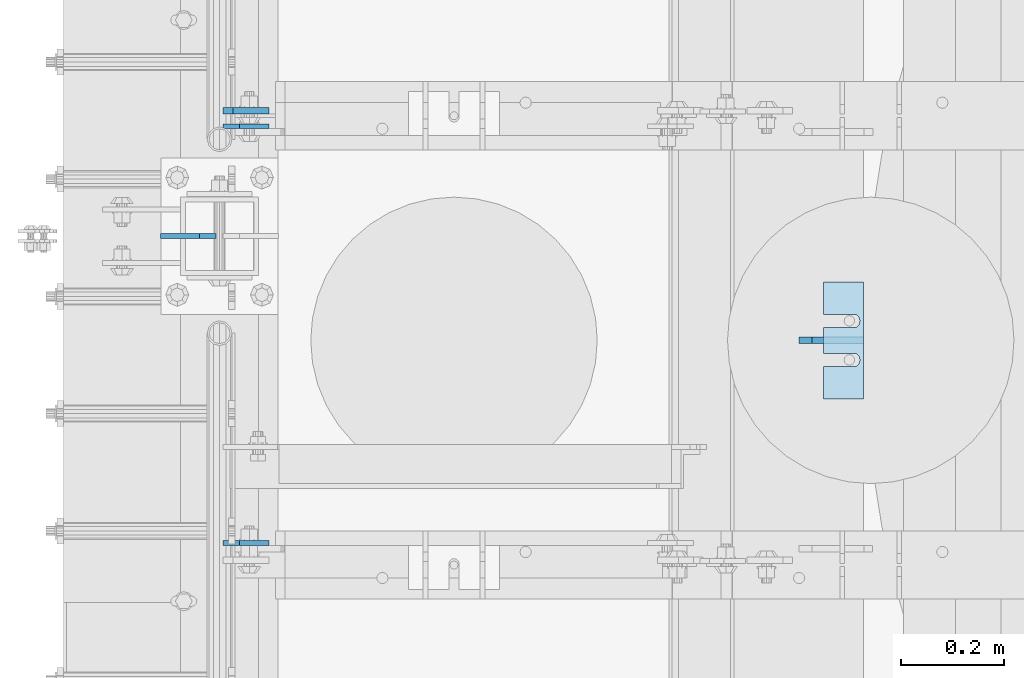
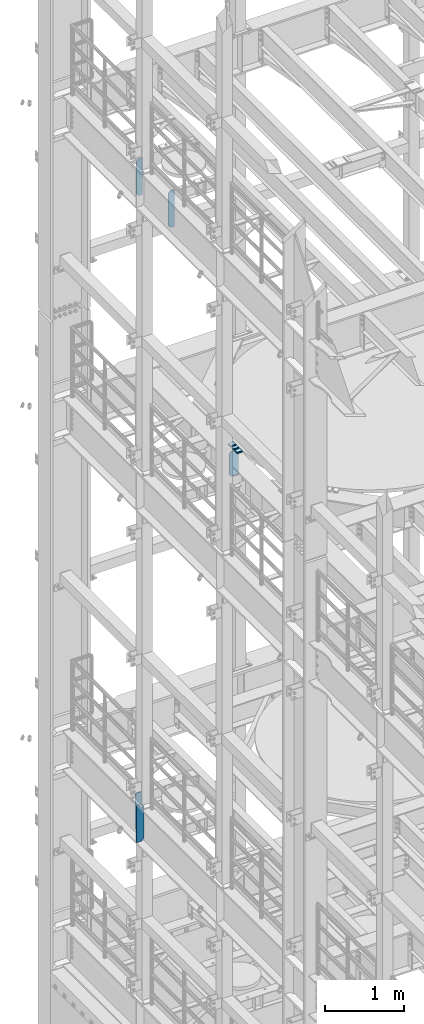
# One storey, part 1757 of 1876: 11 plates, 9 elements without a shape of their own.
"""IFC2X3 building model written with IfcOpenShell, lengths in millimetres."""

from ifc_helpers import new_model, si_unit, frame, origin_with_axes, place, context, subcontext, project, spatial, faceted_brep, material, type_object, element, aggregate, save


model = new_model("IFC2X3")

# Units and contexts
model_context = context("Model", 3, precision=1e-05, world=origin_with_axes())
body_context = subcontext(model_context, "Body", "Model", "MODEL_VIEW")
ifc_project = project(units=[si_unit("LENGTHUNIT", "METRE", prefix="MILLI"), si_unit("AREAUNIT", "SQUARE_METRE"), si_unit("VOLUMEUNIT", "CUBIC_METRE"), si_unit("MASSUNIT", "GRAM", prefix="KILO"), si_unit("TIMEUNIT", "SECOND"), si_unit("PLANEANGLEUNIT", "RADIAN"), si_unit("SOLIDANGLEUNIT", "STERADIAN"), si_unit("THERMODYNAMICTEMPERATUREUNIT", "DEGREE_CELSIUS"), si_unit("LUMINOUSINTENSITYUNIT", "LUMEN")], contexts=[model_context])

# Site, building, storey
site_placement = place(None, origin_with_axes())
site = spatial("IfcSite", under=ifc_project, at=site_placement, CompositionType="ELEMENT")
building_placement = place(site_placement, origin_with_axes())
building = spatial("IfcBuilding", under=site, at=building_placement, Name="Undefined", CompositionType="ELEMENT")
storey_placement = place(building_placement, origin_with_axes())
storey = spatial("IfcBuildingStorey", under=building, at=storey_placement, Name="Undefined", CompositionType="ELEMENT", Elevation=0.0)

# Assembly, plates
assembly_1_placement = place(storey_placement, origin_with_axes())
assembly_1 = element("IfcElementAssembly", 1, at=assembly_1_placement, inside=storey, Name="BEAM", AssemblyPlace="NOTDEFINED", PredefinedType="RIGID_FRAME")
ifc_material = material(Name="STEEL/A36")
plate_type_1 = type_object("IfcPlateType", PredefinedType="NOTDEFINED")
plate_1_placement = place(assembly_1_placement, frame((7.14374999999999, 11085.5129999161, 17386.3), z_axis=(0.0, 0.0, 1.0), x_axis=(1.0, 0.0, 0.0)))
plate_1 = element("IfcPlate", 2, at=plate_1_placement, type_object=plate_type_1, material=ifc_material, Name="PLATE", context=body_context, shape_type="Brep", body=[
    faceted_brep([(-9.76996261670138e-14, -4.76250000000073, 31.75), (0.0, -4.76249999999982, 539.75), (0.0, 4.76249999999982, 539.75), (-9.76996261670138e-14, 4.76250000000073, 31.75), (31.75, -4.76249999999982, 571.5), (31.75, 4.76249999999982, 571.5), (88.9000015258789, -4.76250000000005, 571.5), (88.9000015258789, 4.76250000000005, 571.5), (88.9000015258789, -4.76249999999982, 0.0), (88.9000015258789, 4.76249999999982, 0.0), (31.75, -4.76250000000073, 0.0), (31.75, 4.76250000000073, 0.0)], [[[0, 1, 2, 3]], [[1, 4, 5, 2]], [[4, 6, 7, 5]], [[6, 8, 9, 7]], [[8, 10, 11, 9]], [[10, 0, 3, 11]], [[5, 7, 9, 11, 3, 2]], [[10, 8, 6, 4, 1, 0]]]),
])
plate_2_placement = place(assembly_1_placement, frame((7.14374999999999, 11898.3102777481, 17386.3), z_axis=(0.0, 0.0, 1.0), x_axis=(1.0, 0.0, 0.0)))
plate_2 = element("IfcPlate", 3, at=plate_2_placement, type_object=plate_type_1, material=ifc_material, Name="PLATE", context=body_context, shape_type="Brep", body=[
    faceted_brep([(-9.76996261670138e-14, -4.76250000000073, 31.75), (0.0, -4.76249999999982, 539.75), (0.0, 4.76249999999982, 539.75), (-9.76996261670138e-14, 4.76250000000073, 31.75), (31.75, -4.76249999999982, 571.5), (31.75, 4.76249999999982, 571.5), (88.9000015258789, -4.76250000000005, 571.5), (88.9000015258789, 4.76250000000005, 571.5), (88.9000015258789, -4.76249999999982, 0.0), (88.9000015258789, 4.76249999999982, 0.0), (31.75, -4.76250000000073, 0.0), (31.75, 4.76250000000073, 0.0)], [[[0, 1, 2, 3]], [[1, 4, 5, 2]], [[4, 6, 7, 5]], [[6, 8, 9, 7]], [[8, 10, 11, 9]], [[10, 0, 3, 11]], [[5, 7, 9, 11, 3, 2]], [[10, 8, 6, 4, 1, 0]]]),
])
aggregate(assembly_1, [plate_1, plate_2])

# Assembly, plate
assembly_2_placement = place(storey_placement, origin_with_axes())
assembly_2 = element("IfcElementAssembly", 4, at=assembly_2_placement, inside=storey, Name="BEAM", AssemblyPlace="NOTDEFINED", PredefinedType="RIGID_FRAME")
plate_type_2 = type_object("IfcPlateType", PredefinedType="NOTDEFINED")
plate_3_placement = place(assembly_2_placement, frame((7.14375000000001, 11928.475, 7558.0875), z_axis=(0.0, 0.0, 1.0), x_axis=(1.0, 0.0, 0.0)))
plate_3 = element("IfcPlate", 5, at=plate_3_placement, type_object=plate_type_2, material=ifc_material, Name="PLATE", context=body_context, shape_type="Brep", body=[
    faceted_brep([(0.0, -6.35000000000196, 19.0499992370605), (0.0, -6.34999999999991, 550.862476348877), (0.0, 6.34999999999991, 550.862476348877), (0.0, 6.35000000000105, 19.0499992370605), (19.0499992370605, -6.34999999999991, 569.912475585938), (19.0499992370605, 6.34999999999991, 569.912475585938), (88.9000015258616, -6.35000000001173, 569.912475585938), (88.9000015258634, 6.34999999998627, 569.912475585938), (88.9000015258789, -6.34999999999991, 0.0), (88.9000015258789, 6.34999999999991, 0.0), (19.0499992370642, -6.35000000000105, 0.0), (19.0499992370633, 6.35000000000105, 0.0)], [[[0, 1, 2, 3]], [[1, 4, 5, 2]], [[4, 6, 7, 5]], [[6, 8, 9, 7]], [[8, 10, 11, 9]], [[10, 0, 3, 11]], [[5, 7, 9, 11, 3, 2]], [[10, 8, 6, 4, 1, 0]]]),
])

assembly_3_placement = place(storey_placement, origin_with_axes())
assembly_3 = element("IfcElementAssembly", 6, at=assembly_3_placement, inside=storey, Name="SHIM PLATE", AssemblyPlace="NOTDEFINED", PredefinedType="RIGID_FRAME")
plate_type_3 = type_object("IfcPlateType", PredefinedType="NOTDEFINED")
plate_4_placement = place(assembly_3_placement, frame((1177.56835632324, 11366.5000039719, 13335.7925), z_axis=(2.39509999928487e-05, 0.999999999713175, 0.0), x_axis=(0.999999999713175, -2.395099999284e-05, 0.0)))
plate_4 = element("IfcPlate", 7, at=plate_4_placement, type_object=plate_type_3, material=ifc_material, Name="SHIM PLATE", context=body_context, shape_type="Brep", body=[
    faceted_brep([(-2.69435986410826e-07, -0.793499999999767, 88.9036802523933), (-2.69435986410826e-07, 0.793499999999767, 88.9036802523933), (64.2890073715625, 0.793499999999767, 88.9052190745724), (64.2890073715625, -0.793499999999767, 88.9052190745724), (69.5243873298787, 0.793499999999767, 83.4915584105911), (69.5243873298787, -0.793499999999767, 83.4915584105911), (64.2896161919252, -0.793499999999767, 63.5071916498637), (64.2896161919252, 0.793499999999767, 63.5071916498637), (-1.92456354852766e-07, 0.793499999999767, 63.5036806291719), (-1.92456354852766e-07, -0.793499999999767, 63.5036806291719), (69.5247366006915, -0.793499999999767, 68.9211033039346), (69.5247366006915, 0.793499999999767, 68.9211033039346), (71.4330651893342, -0.793499999999767, 76.2063766063075), (71.4330651893342, 0.793499999999767, 76.2063766063075), (64.2877911166179, -0.793499999999767, 139.707191628078), (64.2877911166179, 0.793499999999767, 139.707191628078), (-4.23393430537544e-07, 0.793499999999767, 139.703680607393), (-4.23393430537544e-07, -0.793499999999767, 139.703680607393), (69.522911525386, -0.793499999999767, 145.12110328215), (69.522911525386, 0.793499999999767, 145.12110328215), (71.4312401140269, -0.793499999999767, 152.406376584524), (71.4312401140269, 0.793499999999767, 152.406376584524), (69.5225622545713, -0.793499999999767, 159.691558388807), (69.5225622545713, 0.793499999999767, 159.691558388807), (64.287182296257, -0.793499999999767, 165.105219052788), (64.287182296257, 0.793499999999767, 165.105219052788), (-5.00373062095605e-07, -0.793499999999767, 165.103680230615), (-5.00373062095605e-07, 0.793499999999767, 165.103680230615), (-6.92811227054335e-07, -0.793499999999767, 228.601303100698), (-6.92811227054335e-07, 0.793499999999767, 228.601303100698), (78.1460113524699, -0.793499999999767, 228.601303100651), (78.1460113524699, 0.793499999999767, 228.601303100651), (78.1460113525918, -0.793499999999767, -4.91127138957381e-11), (78.1460113525918, 0.793499999999767, -4.91127138957381e-11), (9.09494701772928e-13, -0.793499999999767, 0.0), (9.09494701772928e-13, 0.793499999999767, 0.0)], [[[0, 1, 2, 3]], [[3, 2, 4, 5]], [[6, 7, 8, 9]], [[10, 11, 7, 6]], [[12, 13, 11, 10]], [[5, 4, 13, 12]], [[14, 15, 16, 17]], [[18, 19, 15, 14]], [[20, 21, 19, 18]], [[22, 23, 21, 20]], [[24, 25, 23, 22]], [[26, 27, 25, 24]], [[28, 29, 27, 26]], [[28, 30, 31, 29]], [[30, 32, 33, 31]], [[32, 34, 35, 33]], [[35, 34, 9, 8]], [[2, 1, 16, 15, 19, 21, 23, 25, 27, 29, 31, 33, 35, 8, 7, 11, 13, 4]], [[17, 16, 1, 0]], [[6, 9, 34, 32, 30, 28, 26, 24, 22, 20, 18, 14, 17, 0, 3, 5, 12, 10]]]),
])
aggregate(assembly_3, [plate_4])

assembly_4_placement = place(storey_placement, origin_with_axes())
assembly_4 = element("IfcElementAssembly", 8, at=assembly_4_placement, inside=storey, Name="SHIM PLATE", AssemblyPlace="NOTDEFINED", PredefinedType="RIGID_FRAME")
plate_type_4 = type_object("IfcPlateType", PredefinedType="NOTDEFINED")
plate_5_placement = place(assembly_4_placement, frame((1177.56835632324, 11366.5000039719, 13333.4115), z_axis=(2.39509999928487e-05, 0.999999999713175, 0.0), x_axis=(0.999999999713175, -2.395099999284e-05, 0.0)))
plate_5 = element("IfcPlate", 9, at=plate_5_placement, type_object=plate_type_4, material=ifc_material, Name="SHIM PLATE", context=body_context, shape_type="Brep", body=[
    faceted_brep([(-2.69435986410826e-07, -1.58749999999964, 88.9036802523951), (-2.69435986410826e-07, 1.58749999999964, 88.9036802523951), (64.2890073715644, 1.58749999999964, 88.9052190745733), (64.2890073715644, -1.58749999999964, 88.9052190745733), (69.5243873298787, 1.58749999999964, 83.491558410592), (69.5243873298787, -1.58749999999964, 83.491558410592), (64.2896161919234, -1.58749999999964, 63.5071916498646), (64.2896161919234, 1.58749999999964, 63.5071916498646), (-1.92456354852766e-07, 1.58749999999964, 63.5036806291737), (-1.92456354852766e-07, -1.58749999999964, 63.5036806291737), (69.5247366006934, -1.58749999999964, 68.9211033039355), (69.5247366006934, 1.58749999999964, 68.9211033039355), (71.4330651893342, -1.58749999999964, 76.2063766063084), (71.4330651893342, 1.58749999999964, 76.2063766063084), (64.2877911166179, -1.58749999999964, 139.707191628079), (64.2877911166179, 1.58749999999964, 139.707191628079), (-4.23391611548141e-07, 1.58749999999964, 139.703680607395), (-4.23391611548141e-07, -1.58749999999964, 139.703680607395), (69.522911525386, -1.58749999999964, 145.121103282152), (69.522911525386, 1.58749999999964, 145.121103282152), (71.4312401140269, -1.58749999999964, 152.406376584525), (71.4312401140269, 1.58749999999964, 152.406376584525), (69.5225622545713, -1.58749999999964, 159.691558388808), (69.5225622545713, 1.58749999999964, 159.691558388808), (64.2871822962588, -1.58749999999964, 165.105219052789), (64.2871822962588, 1.58749999999964, 165.105219052789), (-5.00371243106201e-07, -1.58749999999964, 165.103680230615), (-5.00371243106201e-07, 1.58749999999964, 165.103680230615), (-6.92813046043739e-07, -1.58749999999964, 228.601303100699), (-6.92813046043739e-07, 1.58749999999964, 228.601303100699), (78.1460113524699, -1.58749999999964, 228.601303100651), (78.1460113524699, 1.58749999999964, 228.601303100651), (78.1460113525918, -1.58749999999964, -4.72937244921923e-11), (78.1460113525918, 1.58749999999964, -4.72937244921923e-11), (9.09494701772928e-13, -1.58750000000146, 4.54747350886464e-13), (9.09494701772928e-13, 1.58750000000146, 4.54747350886464e-13)], [[[0, 1, 2, 3]], [[3, 2, 4, 5]], [[6, 7, 8, 9]], [[10, 11, 7, 6]], [[12, 13, 11, 10]], [[5, 4, 13, 12]], [[14, 15, 16, 17]], [[18, 19, 15, 14]], [[20, 21, 19, 18]], [[22, 23, 21, 20]], [[24, 25, 23, 22]], [[26, 27, 25, 24]], [[28, 29, 27, 26]], [[28, 30, 31, 29]], [[30, 32, 33, 31]], [[32, 34, 35, 33]], [[35, 34, 9, 8]], [[2, 1, 16, 15, 19, 21, 23, 25, 27, 29, 31, 33, 35, 8, 7, 11, 13, 4]], [[17, 16, 1, 0]], [[6, 9, 34, 32, 30, 28, 26, 24, 22, 20, 18, 14, 17, 0, 3, 5, 12, 10]]]),
])
aggregate(assembly_4, [plate_5])

assembly_5_placement = place(storey_placement, origin_with_axes())
assembly_5 = element("IfcElementAssembly", 10, at=assembly_5_placement, inside=storey, Name="SHIM PLATE", AssemblyPlace="NOTDEFINED", PredefinedType="RIGID_FRAME")
plate_6_placement = place(assembly_5_placement, frame((1177.56835632324, 11366.5000039719, 13330.2365), z_axis=(2.39509999928487e-05, 0.999999999713175, 0.0), x_axis=(0.999999999713175, -2.395099999284e-05, 0.0)))
plate_6 = element("IfcPlate", 11, at=plate_6_placement, type_object=plate_type_4, material=ifc_material, Name="SHIM PLATE", context=body_context, shape_type="Brep", body=[
    faceted_brep([(-2.69435986410826e-07, -1.58749999999964, 88.9036802523951), (-2.69435986410826e-07, 1.58749999999964, 88.9036802523951), (64.2890073715644, 1.58749999999964, 88.9052190745733), (64.2890073715644, -1.58749999999964, 88.9052190745733), (69.5243873298787, 1.58749999999964, 83.491558410592), (69.5243873298787, -1.58749999999964, 83.491558410592), (64.2896161919234, -1.58749999999964, 63.5071916498646), (64.2896161919234, 1.58749999999964, 63.5071916498646), (-1.92456354852766e-07, 1.58749999999964, 63.5036806291737), (-1.92456354852766e-07, -1.58749999999964, 63.5036806291737), (69.5247366006934, -1.58749999999964, 68.9211033039355), (69.5247366006934, 1.58749999999964, 68.9211033039355), (71.4330651893342, -1.58749999999964, 76.2063766063084), (71.4330651893342, 1.58749999999964, 76.2063766063084), (64.2877911166179, -1.58749999999964, 139.707191628079), (64.2877911166179, 1.58749999999964, 139.707191628079), (-4.23391611548141e-07, 1.58749999999964, 139.703680607395), (-4.23391611548141e-07, -1.58749999999964, 139.703680607395), (69.522911525386, -1.58749999999964, 145.121103282152), (69.522911525386, 1.58749999999964, 145.121103282152), (71.4312401140269, -1.58749999999964, 152.406376584525), (71.4312401140269, 1.58749999999964, 152.406376584525), (69.5225622545713, -1.58749999999964, 159.691558388808), (69.5225622545713, 1.58749999999964, 159.691558388808), (64.2871822962588, -1.58749999999964, 165.105219052789), (64.2871822962588, 1.58749999999964, 165.105219052789), (-5.00371243106201e-07, -1.58749999999964, 165.103680230615), (-5.00371243106201e-07, 1.58749999999964, 165.103680230615), (-6.92813046043739e-07, -1.58749999999964, 228.601303100699), (-6.92813046043739e-07, 1.58749999999964, 228.601303100699), (78.1460113524699, -1.58749999999964, 228.601303100651), (78.1460113524699, 1.58749999999964, 228.601303100651), (78.1460113525918, -1.58749999999964, -4.72937244921923e-11), (78.1460113525918, 1.58749999999964, -4.72937244921923e-11), (9.09494701772928e-13, -1.58750000000146, 4.54747350886464e-13), (9.09494701772928e-13, 1.58750000000146, 4.54747350886464e-13)], [[[0, 1, 2, 3]], [[3, 2, 4, 5]], [[6, 7, 8, 9]], [[10, 11, 7, 6]], [[12, 13, 11, 10]], [[5, 4, 13, 12]], [[14, 15, 16, 17]], [[18, 19, 15, 14]], [[20, 21, 19, 18]], [[22, 23, 21, 20]], [[24, 25, 23, 22]], [[26, 27, 25, 24]], [[28, 29, 27, 26]], [[28, 30, 31, 29]], [[30, 32, 33, 31]], [[32, 34, 35, 33]], [[35, 34, 9, 8]], [[2, 1, 16, 15, 19, 21, 23, 25, 27, 29, 31, 33, 35, 8, 7, 11, 13, 4]], [[17, 16, 1, 0]], [[6, 9, 34, 32, 30, 28, 26, 24, 22, 20, 18, 14, 17, 0, 3, 5, 12, 10]]]),
])
aggregate(assembly_5, [plate_6])

assembly_6_placement = place(storey_placement, origin_with_axes())
assembly_6 = element("IfcElementAssembly", 12, at=assembly_6_placement, inside=storey, Name="SHIM PLATE", AssemblyPlace="NOTDEFINED", PredefinedType="RIGID_FRAME")
plate_type_5 = type_object("IfcPlateType", PredefinedType="NOTDEFINED")
plate_7_placement = place(assembly_6_placement, frame((1177.56835632324, 11366.5000039719, 13326.268), z_axis=(2.39509999928487e-05, 0.999999999713175, 0.0), x_axis=(0.999999999713175, -2.395099999284e-05, 0.0)))
plate_7 = element("IfcPlate", 13, at=plate_7_placement, type_object=plate_type_5, material=ifc_material, Name="SHIM PLATE", context=body_context, shape_type="Brep", body=[
    faceted_brep([(-2.69435986410826e-07, -2.3809999999994, 88.9036802523951), (-2.69435986410826e-07, 2.3809999999994, 88.9036802523951), (64.2890073715644, 2.3809999999994, 88.9052190745733), (64.2890073715644, -2.3809999999994, 88.9052190745733), (69.5243873298787, 2.3809999999994, 83.491558410592), (69.5243873298787, -2.3809999999994, 83.491558410592), (64.2896161919234, -2.3809999999994, 63.5071916498646), (64.2896161919234, 2.3809999999994, 63.5071916498646), (-1.92456354852766e-07, 2.3809999999994, 63.5036806291737), (-1.92456354852766e-07, -2.3809999999994, 63.5036806291737), (69.5247366006934, -2.3809999999994, 68.9211033039355), (69.5247366006934, 2.3809999999994, 68.9211033039355), (71.4330651893342, -2.3809999999994, 76.2063766063084), (71.4330651893342, 2.3809999999994, 76.2063766063084), (64.2877911166179, -2.3809999999994, 139.707191628079), (64.2877911166179, 2.3809999999994, 139.707191628079), (-4.23391611548141e-07, 2.3809999999994, 139.703680607395), (-4.23391611548141e-07, -2.3809999999994, 139.703680607395), (69.522911525386, -2.3809999999994, 145.121103282152), (69.522911525386, 2.3809999999994, 145.121103282152), (71.4312401140269, -2.3809999999994, 152.406376584525), (71.4312401140269, 2.3809999999994, 152.406376584525), (69.5225622545713, -2.3809999999994, 159.691558388808), (69.5225622545713, 2.3809999999994, 159.691558388808), (64.2871822962588, -2.3809999999994, 165.105219052789), (64.2871822962588, 2.3809999999994, 165.105219052789), (-5.00371243106201e-07, -2.3809999999994, 165.103680230615), (-5.00371243106201e-07, 2.3809999999994, 165.103680230615), (-6.92813046043739e-07, -2.3809999999994, 228.601303100699), (-6.92813046043739e-07, 2.3809999999994, 228.601303100699), (78.1460113524699, -2.3809999999994, 228.601303100651), (78.1460113524699, 2.3809999999994, 228.601303100651), (78.1460113525918, -2.3809999999994, -4.72937244921923e-11), (78.1460113525918, 2.3809999999994, -4.72937244921923e-11), (0.0, -2.38100000000122, 4.54747350886464e-13), (0.0, 2.38100000000122, 4.54747350886464e-13)], [[[0, 1, 2, 3]], [[3, 2, 4, 5]], [[6, 7, 8, 9]], [[10, 11, 7, 6]], [[12, 13, 11, 10]], [[5, 4, 13, 12]], [[14, 15, 16, 17]], [[18, 19, 15, 14]], [[20, 21, 19, 18]], [[22, 23, 21, 20]], [[24, 25, 23, 22]], [[26, 27, 25, 24]], [[28, 29, 27, 26]], [[28, 30, 31, 29]], [[30, 32, 33, 31]], [[32, 34, 35, 33]], [[35, 34, 9, 8]], [[2, 1, 16, 15, 19, 21, 23, 25, 27, 29, 31, 33, 35, 8, 7, 11, 13, 4]], [[17, 16, 1, 0]], [[6, 9, 34, 32, 30, 28, 26, 24, 22, 20, 18, 14, 17, 0, 3, 5, 12, 10]]]),
])
aggregate(assembly_6, [plate_7])

assembly_7_placement = place(storey_placement, origin_with_axes())
assembly_7 = element("IfcElementAssembly", 14, at=assembly_7_placement, inside=storey, Name="SHIM PLATE", AssemblyPlace="NOTDEFINED", PredefinedType="RIGID_FRAME")
plate_8_placement = place(assembly_7_placement, frame((1177.56835632324, 11366.5000039719, 13321.506), z_axis=(2.39509999928487e-05, 0.999999999713175, 0.0), x_axis=(0.999999999713175, -2.395099999284e-05, 0.0)))
plate_8 = element("IfcPlate", 15, at=plate_8_placement, type_object=plate_type_5, material=ifc_material, Name="SHIM PLATE", context=body_context, shape_type="Brep", body=[
    faceted_brep([(-2.69435986410826e-07, -2.3809999999994, 88.9036802523951), (-2.69435986410826e-07, 2.3809999999994, 88.9036802523951), (64.2890073715644, 2.3809999999994, 88.9052190745733), (64.2890073715644, -2.3809999999994, 88.9052190745733), (69.5243873298787, 2.3809999999994, 83.491558410592), (69.5243873298787, -2.3809999999994, 83.491558410592), (64.2896161919234, -2.3809999999994, 63.5071916498646), (64.2896161919234, 2.3809999999994, 63.5071916498646), (-1.92456354852766e-07, 2.3809999999994, 63.5036806291737), (-1.92456354852766e-07, -2.3809999999994, 63.5036806291737), (69.5247366006934, -2.3809999999994, 68.9211033039355), (69.5247366006934, 2.3809999999994, 68.9211033039355), (71.4330651893342, -2.3809999999994, 76.2063766063084), (71.4330651893342, 2.3809999999994, 76.2063766063084), (64.2877911166179, -2.3809999999994, 139.707191628079), (64.2877911166179, 2.3809999999994, 139.707191628079), (-4.23391611548141e-07, 2.3809999999994, 139.703680607395), (-4.23391611548141e-07, -2.3809999999994, 139.703680607395), (69.522911525386, -2.3809999999994, 145.121103282152), (69.522911525386, 2.3809999999994, 145.121103282152), (71.4312401140269, -2.3809999999994, 152.406376584525), (71.4312401140269, 2.3809999999994, 152.406376584525), (69.5225622545713, -2.3809999999994, 159.691558388808), (69.5225622545713, 2.3809999999994, 159.691558388808), (64.2871822962588, -2.3809999999994, 165.105219052789), (64.2871822962588, 2.3809999999994, 165.105219052789), (-5.00371243106201e-07, -2.3809999999994, 165.103680230615), (-5.00371243106201e-07, 2.3809999999994, 165.103680230615), (-6.92813046043739e-07, -2.3809999999994, 228.601303100699), (-6.92813046043739e-07, 2.3809999999994, 228.601303100699), (78.1460113524699, -2.3809999999994, 228.601303100651), (78.1460113524699, 2.3809999999994, 228.601303100651), (78.1460113525918, -2.3809999999994, -4.72937244921923e-11), (78.1460113525918, 2.3809999999994, -4.72937244921923e-11), (0.0, -2.38100000000122, 4.54747350886464e-13), (0.0, 2.38100000000122, 4.54747350886464e-13)], [[[0, 1, 2, 3]], [[3, 2, 4, 5]], [[6, 7, 8, 9]], [[10, 11, 7, 6]], [[12, 13, 11, 10]], [[5, 4, 13, 12]], [[14, 15, 16, 17]], [[18, 19, 15, 14]], [[20, 21, 19, 18]], [[22, 23, 21, 20]], [[24, 25, 23, 22]], [[26, 27, 25, 24]], [[28, 29, 27, 26]], [[28, 30, 31, 29]], [[30, 32, 33, 31]], [[32, 34, 35, 33]], [[35, 34, 9, 8]], [[2, 1, 16, 15, 19, 21, 23, 25, 27, 29, 31, 33, 35, 8, 7, 11, 13, 4]], [[17, 16, 1, 0]], [[6, 9, 34, 32, 30, 28, 26, 24, 22, 20, 18, 14, 17, 0, 3, 5, 12, 10]]]),
])
aggregate(assembly_7, [plate_8])

assembly_8_placement = place(storey_placement, origin_with_axes())
assembly_8 = element("IfcElementAssembly", 16, at=assembly_8_placement, inside=storey, Name="SHIM PLATE", AssemblyPlace="NOTDEFINED", PredefinedType="RIGID_FRAME")
plate_type_6 = type_object("IfcPlateType", PredefinedType="NOTDEFINED")
plate_9_placement = place(assembly_8_placement, frame((1177.56835632324, 11366.5000039719, 13314.3625), z_axis=(2.39509999928487e-05, 0.999999999713175, 0.0), x_axis=(0.999999999713175, -2.395099999284e-05, 0.0)))
plate_9 = element("IfcPlate", 17, at=plate_9_placement, type_object=plate_type_6, material=ifc_material, Name="SHIM PLATE", context=body_context, shape_type="Brep", body=[
    faceted_brep([(-2.69435986410826e-07, -4.76250000000073, 88.9036802523951), (-2.69435986410826e-07, 4.76250000000073, 88.9036802523951), (64.2890073715644, 4.76250000000073, 88.9052190745733), (64.2890073715644, -4.76250000000073, 88.9052190745733), (69.5243873298787, 4.76250000000073, 83.491558410592), (69.5243873298787, -4.76250000000073, 83.491558410592), (64.2896161919234, -4.76250000000073, 63.5071916498646), (64.2896161919234, 4.76250000000073, 63.5071916498646), (-1.92456354852766e-07, 4.76250000000073, 63.5036806291737), (-1.92456354852766e-07, -4.76250000000073, 63.5036806291737), (69.5247366006934, -4.76250000000073, 68.9211033039355), (69.5247366006934, 4.76250000000073, 68.9211033039355), (71.4330651893342, -4.76250000000073, 76.2063766063084), (71.4330651893342, 4.76250000000073, 76.2063766063084), (64.2877911166179, -4.76250000000073, 139.707191628079), (64.2877911166179, 4.76250000000073, 139.707191628079), (-4.23391611548141e-07, 4.76250000000073, 139.703680607395), (-4.23391611548141e-07, -4.76250000000073, 139.703680607395), (69.522911525386, -4.76250000000073, 145.121103282152), (69.522911525386, 4.76250000000073, 145.121103282152), (71.4312401140269, -4.76250000000073, 152.406376584525), (71.4312401140269, 4.76250000000073, 152.406376584525), (69.5225622545713, -4.76250000000073, 159.691558388808), (69.5225622545713, 4.76250000000073, 159.691558388808), (64.2871822962588, -4.76250000000073, 165.105219052789), (64.2871822962588, 4.76250000000073, 165.105219052789), (-5.00371243106201e-07, -4.76250000000073, 165.103680230615), (-5.00371243106201e-07, 4.76250000000073, 165.103680230615), (-6.92813046043739e-07, -4.76250000000073, 228.601303100699), (-6.92813046043739e-07, 4.76250000000073, 228.601303100699), (78.1460113524699, -4.76250000000073, 228.601303100651), (78.1460113524699, 4.76250000000073, 228.601303100651), (78.1460113525918, -4.76250000000073, -4.72937244921923e-11), (78.1460113525918, 4.76250000000073, -4.72937244921923e-11), (0.0, -4.76249999999982, 0.0), (0.0, 4.76249999999982, 0.0)], [[[0, 1, 2, 3]], [[3, 2, 4, 5]], [[6, 7, 8, 9]], [[10, 11, 7, 6]], [[12, 13, 11, 10]], [[5, 4, 13, 12]], [[14, 15, 16, 17]], [[18, 19, 15, 14]], [[20, 21, 19, 18]], [[22, 23, 21, 20]], [[24, 25, 23, 22]], [[26, 27, 25, 24]], [[28, 29, 27, 26]], [[28, 30, 31, 29]], [[30, 32, 33, 31]], [[32, 34, 35, 33]], [[35, 34, 9, 8]], [[2, 1, 16, 15, 19, 21, 23, 25, 27, 29, 31, 33, 35, 8, 7, 11, 13, 4]], [[17, 16, 1, 0]], [[6, 9, 34, 32, 30, 28, 26, 24, 22, 20, 18, 14, 17, 0, 3, 5, 12, 10]]]),
])
aggregate(assembly_8, [plate_9])

# Plate
plate_type_7 = type_object("IfcPlateType", PredefinedType="NOTDEFINED")
plate_10_placement = place(assembly_2_placement, frame((-7.14374999999999, 11684.0, 7556.5), z_axis=(0.0, 0.0, 1.0), x_axis=(-1.0, 0.0, 0.0)))
plate_10 = element("IfcPlate", 18, at=plate_10_placement, type_object=plate_type_7, material=ifc_material, Name="PLATE", context=body_context, shape_type="Brep", body=[
    faceted_brep([(-9.76996261670138e-14, -4.76250000000073, 31.75), (0.0, -4.76249999999982, 539.75), (0.0, 4.76249999999982, 539.75), (-9.76996261670138e-14, 4.76250000000073, 31.75), (31.75, -4.76249999999982, 571.5), (31.75, 4.76249999999982, 571.5), (107.949996948242, -4.76249999999982, 571.5), (107.949996948242, 4.76249999999982, 571.5), (107.950006484985, -4.76250000000073, 0.0), (107.950006484985, 4.76250000000073, 0.0), (31.75, -4.76250000000073, 0.0), (31.75, 4.76250000000073, 0.0)], [[[0, 1, 2, 3]], [[1, 4, 5, 2]], [[4, 6, 7, 5]], [[6, 8, 9, 7]], [[8, 10, 11, 9]], [[10, 0, 3, 11]], [[5, 7, 9, 11, 3, 2]], [[10, 8, 6, 4, 1, 0]]]),
])

aggregate(assembly_2, [plate_10, plate_3])

# Assembly, plate
assembly_9_placement = place(storey_placement, origin_with_axes())
assembly_9 = element("IfcElementAssembly", 19, at=assembly_9_placement, inside=storey, Name="BEAM", AssemblyPlace="NOTDEFINED", PredefinedType="RIGID_FRAME")
plate_type_8 = type_object("IfcPlateType", PredefinedType="NOTDEFINED")
plate_11_placement = place(assembly_9_placement, frame((1255.71250480063, 11480.8, 12906.375), z_axis=(0.0, 0.0, 1.0), x_axis=(-1.0, 0.0, 0.0)))
plate_11 = element("IfcPlate", 20, at=plate_11_placement, type_object=plate_type_8, material=ifc_material, Name="PLATE", context=body_context, shape_type="Brep", body=[
    faceted_brep([(0.0, -6.35000000000036, 0.0), (0.0, -6.35000000000036, 381.0), (0.0, 6.35000000000036, 381.0), (0.0, 6.35000000000036, 0.0), (100.012498855591, -6.35000000000036, 381.0), (100.012498855591, 6.35000000000036, 381.0), (125.412498474121, -6.35000000000036, 355.60000038147), (125.412498474121, 6.35000000000036, 355.60000038147), (125.412498474121, -6.35000000000036, 25.3999996185303), (125.412498474121, 6.35000000000036, 25.3999996185303), (100.012498855591, -6.35000000000036, 0.0), (100.012498855591, 6.35000000000036, 0.0)], [[[0, 1, 2, 3]], [[1, 4, 5, 2]], [[4, 6, 7, 5]], [[6, 8, 9, 7]], [[8, 10, 11, 9]], [[10, 0, 3, 11]], [[5, 7, 9, 11, 3, 2]], [[10, 8, 6, 4, 1, 0]]]),
])
aggregate(assembly_9, [plate_11])

save(model, "model.ifc")
